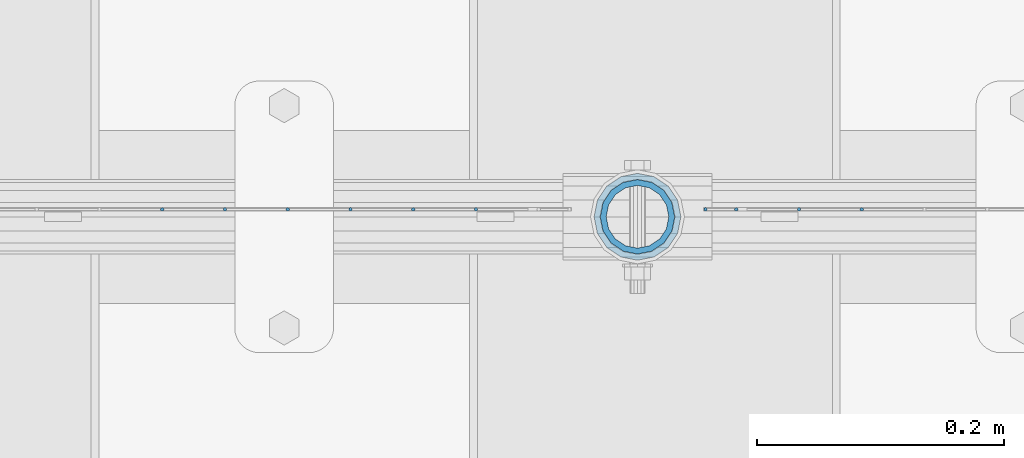
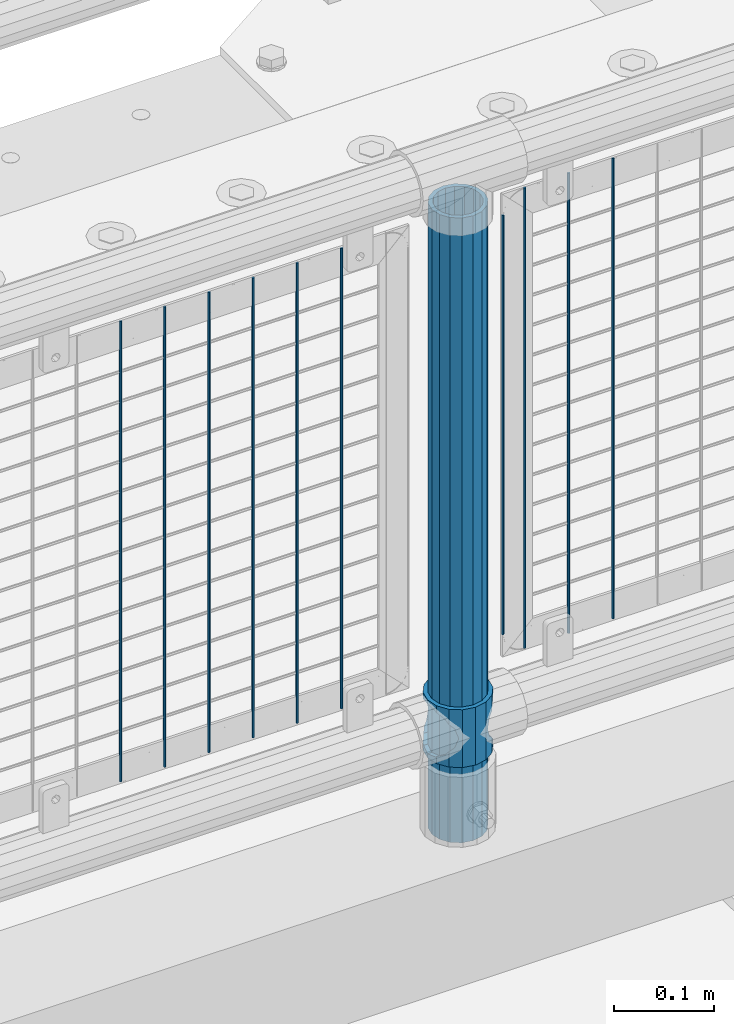
# One storey, part 79 of 242: 12 columns.
"""IFC2X3 building model written with IfcOpenShell, lengths in millimetres."""

import ifcopenshell
import ifcopenshell.guid

model = None  # the IFC model being written
_history = None  # IfcOwnerHistory: only IFC2X3 demands one
_inside = {}  # id of a spatial element -> (the spatial element, [elements in it])
_under = {}  # id of a project, library or spatial element -> (it, [spatial elements below it])
_declared = {}  # id of a project -> (the project, [libraries it declares])
_typed = {}  # id of a type object -> (the type object, [elements of that type])
_made_of = {}  # id of a material, layer set ... -> (it, [elements and type objects made of it])


def new_model(schema):
    """Start an empty IFC model of exactly this schema.

    Asked for "IFC4X3", IfcOpenShell would pick the latest addendum, in which some entities
    have other attributes; the version numbers below select the first issue.
    IFC2X3 requires an IfcOwnerHistory on every rooted entity: one is made here for all.
    """
    global model, _history
    if schema == "IFC4X3":
        model = ifcopenshell.file(schema_version=(4, 3, 0, 0))
    else:
        model = ifcopenshell.file(schema=schema)
    _inside.clear()
    _under.clear()
    _declared.clear()
    _typed.clear()
    _made_of.clear()
    _history = None
    if model.schema == "IFC2X3":
        org = make("IfcOrganization", Name="unknown")
        user = make(
            "IfcPersonAndOrganization",
            ThePerson=make("IfcPerson", FamilyName="unknown"),
            TheOrganization=org,
        )
        app = make(
            "IfcApplication",
            ApplicationDeveloper=org,
            Version="unknown",
            ApplicationFullName="unknown",
            ApplicationIdentifier="unknown",
        )
        _history = make(
            "IfcOwnerHistory",
            OwningUser=user,
            OwningApplication=app,
            ChangeAction="ADDED",
            CreationDate=0,
        )
    return model


def make(cls, **values):
    """One entity of the class cls with the attributes given. An attribute that is None is left unset."""
    return model.create_entity(
        cls, **{name: value for name, value in values.items() if value is not None}
    )


def rooted(cls, **values):
    """An entity with a GlobalId (a new one), such as an element, a storey or a relation."""
    return make(cls, GlobalId=ifcopenshell.guid.new(), OwnerHistory=_history, **values)


def si_unit(unit_type, name, prefix=None):
    """IfcSIUnit, for example si_unit("LENGTHUNIT", "METRE", prefix="MILLI")."""
    return make("IfcSIUnit", UnitType=unit_type, Prefix=prefix, Name=name)


def assignment(units):
    """IfcUnitAssignment: the units of a project."""
    return None if units is None else make("IfcUnitAssignment", Units=units)


def point(xyz):
    """IfcCartesianPoint."""
    return None if xyz is None else make("IfcCartesianPoint", Coordinates=xyz)


def direction(xyz):
    """IfcDirection."""
    return None if xyz is None else make("IfcDirection", DirectionRatios=xyz)


def frame(location, z_axis=None, x_axis=None):
    """IfcAxis2Placement3D, a coordinate frame: its origin and axes. An axis left out is left unset."""
    return make(
        "IfcAxis2Placement3D",
        Location=point(location),
        Axis=direction(z_axis),
        RefDirection=direction(x_axis),
    )


def origin_with_axes():
    """The frame at (0, 0, 0) with the z axis (0, 0, 1) and the x axis (1, 0, 0) written out."""
    return frame((0.0, 0.0, 0.0), z_axis=(0.0, 0.0, 1.0), x_axis=(1.0, 0.0, 0.0))


def place(relative_to, where):
    """IfcLocalPlacement: puts the frame where relative to a parent placement (None: the world)."""
    return make(
        "IfcLocalPlacement", PlacementRelTo=relative_to, RelativePlacement=where
    )


def context(
    kind, dimensions, precision=None, world=None, true_north=None, identifier=None
):
    """IfcGeometricRepresentationContext, for example the 3D "Model" context."""
    return make(
        "IfcGeometricRepresentationContext",
        ContextIdentifier=identifier,
        ContextType=kind,
        CoordinateSpaceDimension=dimensions,
        Precision=precision,
        WorldCoordinateSystem=world,
        TrueNorth=true_north,
    )


def subcontext(parent, identifier, kind, view, scale=None):
    """IfcGeometricRepresentationSubContext, for example "Body" below "Model"."""
    return make(
        "IfcGeometricRepresentationSubContext",
        ContextIdentifier=identifier,
        ContextType=kind,
        ParentContext=parent,
        TargetScale=scale,
        TargetView=view,
    )


def project(units=None, contexts=None):
    """IfcProject with its units and contexts."""
    return rooted(
        "IfcProject",
        Name="project",
        RepresentationContexts=contexts,
        UnitsInContext=assignment(units),
    )


def spatial(cls, under=None, at=None, **own):
    """A site, building, storey or space (cls), placed at a placement, below another one or the project."""
    s = rooted(cls, ObjectPlacement=at, **own)
    if under is not None:
        _under.setdefault(under.id(), (under, []))[1].append(s)
    return s


def faces_of(points, faces, orient=None, outer=None):
    """IfcFace entities. A face is a list of loops; a loop is a list of indices into points, from 0.

    orient and outer hold one flag for each loop. By default every Orientation is true, the
    first loop of a face is its IfcFaceOuterBound and the others are IfcFaceBound.
    """
    made = []
    for i, loops in enumerate(faces):
        bounds = []
        for j, loop in enumerate(loops):
            is_outer = j == 0 if outer is None else outer[i][j]
            bounds.append(
                make(
                    "IfcFaceOuterBound" if is_outer else "IfcFaceBound",
                    Bound=make("IfcPolyLoop", Polygon=[points[k] for k in loop]),
                    Orientation=True if orient is None else orient[i][j],
                )
            )
        made.append(make("IfcFace", Bounds=bounds))
    return made


def faceted_brep(points, faces, orient=None, outer=None, voids=None):
    """IfcFacetedBrep: a solid bounded by flat faces; with voids (closed shells), ...WithVoids."""
    shared = [point(p) for p in points]
    hull = make("IfcClosedShell", CfsFaces=faces_of(shared, faces, orient, outer))
    if voids is None:
        return make("IfcFacetedBrep", Outer=hull)
    return make(
        "IfcFacetedBrepWithVoids",
        Outer=hull,
        Voids=[
            make(cls, CfsFaces=faces_of(shared, fs, o, b)) for cls, fs, o, b in voids
        ],
    )


def shape(context_of_items, identifier, shape_type, items):
    """IfcShapeRepresentation: the items that make up one representation, for example the "Body"."""
    return make(
        "IfcShapeRepresentation",
        ContextOfItems=context_of_items,
        RepresentationIdentifier=identifier,
        RepresentationType=shape_type,
        Items=items,
    )


def material(Name=None, Category=None):
    """IfcMaterial."""
    return make("IfcMaterial", Name=Name, Category=Category)


def made_of(thing, what):
    """Note that an element or type object is made of a material, layer set ...; save() writes the relation."""
    if what is not None:
        _made_of.setdefault(what.id(), (what, []))[1].append(thing)
    return thing


def type_object(cls, material=None, **own):
    """A type object (cls), such as IfcWallType, which elements share."""
    return made_of(rooted(cls, **own), material)


def element(
    cls,
    number,
    at=None,
    inside=None,
    cuts=None,
    type_object=None,
    material=None,
    context=None,
    identifier="Body",
    shape_type=None,
    held_by="IfcProductDefinitionShape",
    body=None,
    shapes=None,
    **own,
):
    """One element of the class cls, such as IfcWall. Its Tag is "e" and its number.

    at: its placement. inside: the storey or other place that contains it. cuts: it is an
    opening in that element (IfcRelVoidsElement). A single representation is given by context,
    identifier, shape_type and body (its items); several are given by shapes. held_by: the class
    of the entity that holds the representations. save() writes the other relations.
    """
    e = rooted(cls, Tag="e%d" % number, ObjectPlacement=at, **own)
    if body is not None:
        shapes = [shape(context, identifier, shape_type, body)]
    if shapes is not None:
        e.Representation = make(held_by, Representations=shapes)
    if inside is not None:
        _inside.setdefault(inside.id(), (inside, []))[1].append(e)
    if cuts is not None:
        rooted(
            "IfcRelVoidsElement", RelatingBuildingElement=cuts, RelatedOpeningElement=e
        )
    if type_object is not None:
        _typed.setdefault(type_object.id(), (type_object, []))[1].append(e)
    return made_of(e, material)


def aggregate(whole, parts):
    """IfcRelAggregates: a whole, such as a stair, and the parts it consists of."""
    return rooted("IfcRelAggregates", RelatingObject=whole, RelatedObjects=parts)


def save(model, path):
    """Write the relations noted so far, then the file.

    IfcRelAggregates (storeys below a building ...), IfcRelContainedInSpatialStructure (elements
    in a storey), IfcRelDefinesByType, IfcRelAssociatesMaterial and IfcRelDeclares: one each for
    every whole, place, type object, material and project.
    """
    for whole, parts in _under.values():
        aggregate(whole, parts)
    for where, things in _inside.values():
        rooted(
            "IfcRelContainedInSpatialStructure",
            RelatedElements=things,
            RelatingStructure=where,
        )
    for kind, things in _typed.values():
        rooted("IfcRelDefinesByType", RelatedObjects=things, RelatingType=kind)
    for what, things in _made_of.values():
        rooted("IfcRelAssociatesMaterial", RelatedObjects=things, RelatingMaterial=what)
    for by, libraries in _declared.values():
        rooted("IfcRelDeclares", RelatingContext=by, RelatedDefinitions=libraries)
    model.write(path)


model = new_model("IFC2X3")

# Units and contexts
model_context = context("Model", 3, precision=1e-05, world=origin_with_axes())
body_context = subcontext(model_context, "Body", "Model", "MODEL_VIEW")
ifc_project = project(units=[si_unit("LENGTHUNIT", "METRE", prefix="MILLI"), si_unit("AREAUNIT", "SQUARE_METRE"), si_unit("VOLUMEUNIT", "CUBIC_METRE"), si_unit("MASSUNIT", "GRAM", prefix="KILO"), si_unit("TIMEUNIT", "SECOND"), si_unit("PLANEANGLEUNIT", "RADIAN"), si_unit("SOLIDANGLEUNIT", "STERADIAN"), si_unit("THERMODYNAMICTEMPERATUREUNIT", "DEGREE_CELSIUS"), si_unit("LUMINOUSINTENSITYUNIT", "LUMEN")], contexts=[model_context])

# Site, building, storey
site_placement = place(None, origin_with_axes())
site = spatial("IfcSite", under=ifc_project, at=site_placement, CompositionType="ELEMENT")
building_placement = place(site_placement, origin_with_axes())
building = spatial("IfcBuilding", under=site, at=building_placement, Name="Standard", CompositionType="ELEMENT")
storey_placement = place(building_placement, origin_with_axes())
storey = spatial("IfcBuildingStorey", under=building, at=storey_placement, Name="Undefined", CompositionType="ELEMENT", Elevation=0.0)

# Columns
ifc_material_1 = material()
column_type_1 = type_object("IfcColumnType", PredefinedType="NOTDEFINED")
column_1_placement = place(storey_placement, frame((-33664.0, -19335.5, 168.02), z_axis=(-1.0, 0.0, 0.0), x_axis=(0.0, 0.0, 1.0)))
element("IfcColumn", 1, at=column_1_placement, inside=storey, type_object=column_type_1, material=ifc_material_1, context=body_context, shape_type="Brep", body=[
    faceted_brep([(0.0, -25.3499999999985, 0.0), (0.0, -23.4203461491597, 9.70102501045403), (760.0, -23.4203461491597, 9.70102501045403), (760.0, -25.3499999999985, 0.0), (0.0, -17.9251569030785, 17.9251569030785), (760.0, -17.9251569030785, 17.9251569030785), (0.0, -9.70102501045403, 23.4203461491597), (760.0, -9.70102501045403, 23.4203461491597), (0.0, 0.0, 25.3499999999985), (760.0, 0.0, 25.3499999999985), (0.0, 9.70102501045403, 23.4203461491597), (760.0, 9.70102501045403, 23.4203461491597), (0.0, 17.9251569030785, 17.9251569030785), (760.0, 17.9251569030785, 17.9251569030785), (0.0, 23.4203461491597, 9.70102501045403), (760.0, 23.4203461491597, 9.70102501045403), (0.0, 25.3499999999985, 0.0), (760.0, 25.3499999999985, 0.0), (0.0, 23.4203461491597, -9.70102501045403), (760.0, 23.4203461491597, -9.70102501045403), (0.0, 17.9251569030785, -17.9251569030785), (760.0, 17.9251569030785, -17.9251569030785), (0.0, 9.70102501045403, -23.4203461491597), (760.0, 9.70102501045403, -23.4203461491597), (0.0, 0.0, -25.3499999999985), (760.0, 0.0, -25.3499999999985), (0.0, -9.70102501045403, -23.4203461491597), (760.0, -9.70102501045403, -23.4203461491597), (0.0, -17.9251569030785, -17.9251569030785), (760.0, -17.9251569030785, -17.9251569030785), (0.0, -23.4203461491597, -9.70102501045403), (760.0, -23.4203461491597, -9.70102501045403), (0.0, -30.1500000000015, 0.0), (0.0, -27.8549679052157, -11.5379054858058), (760.0, -27.8549679052157, -11.5379054858058), (760.0, -30.1500000000015, 0.0), (0.0, -21.3192694527752, -21.3192694527752), (760.0, -21.3192694527752, -21.3192694527752), (0.0, -11.5379054858058, -27.8549679052157), (760.0, -11.5379054858058, -27.8549679052157), (0.0, 0.0, -30.1500000000015), (760.0, 0.0, -30.1500000000015), (0.0, 11.5379054858058, -27.8549679052157), (760.0, 11.5379054858058, -27.8549679052157), (0.0, 21.3192694527752, -21.3192694527752), (760.0, 21.3192694527752, -21.3192694527752), (0.0, 27.8549679052157, -11.5379054858058), (760.0, 27.8549679052157, -11.5379054858058), (0.0, 30.1500000000015, 0.0), (760.0, 30.1500000000015, 0.0), (0.0, 27.8549679052157, 11.5379054858058), (760.0, 27.8549679052157, 11.5379054858058), (0.0, 21.3192694527752, 21.3192694527752), (760.0, 21.3192694527752, 21.3192694527752), (0.0, 11.5379054858058, 27.8549679052157), (760.0, 11.5379054858058, 27.8549679052157), (0.0, 0.0, 30.1500000000015), (760.0, 0.0, 30.1500000000015), (0.0, -11.5379054858058, 27.8549679052157), (760.0, -11.5379054858058, 27.8549679052157), (0.0, -21.3192694527752, 21.3192694527752), (760.0, -21.3192694527752, 21.3192694527752), (0.0, -27.8549679052157, 11.5379054858058), (760.0, -27.8549679052157, 11.5379054858058)], [[[0, 1, 2, 3]], [[1, 4, 5, 2]], [[4, 6, 7, 5]], [[6, 8, 9, 7]], [[8, 10, 11, 9]], [[10, 12, 13, 11]], [[12, 14, 15, 13]], [[14, 16, 17, 15]], [[16, 18, 19, 17]], [[18, 20, 21, 19]], [[20, 22, 23, 21]], [[22, 24, 25, 23]], [[24, 26, 27, 25]], [[26, 28, 29, 27]], [[28, 30, 31, 29]], [[30, 0, 3, 31]], [[32, 33, 34, 35]], [[33, 36, 37, 34]], [[36, 38, 39, 37]], [[38, 40, 41, 39]], [[40, 42, 43, 41]], [[42, 44, 45, 43]], [[44, 46, 47, 45]], [[46, 48, 49, 47]], [[48, 50, 51, 49]], [[50, 52, 53, 51]], [[52, 54, 55, 53]], [[54, 56, 57, 55]], [[56, 58, 59, 57]], [[58, 60, 61, 59]], [[60, 62, 63, 61]], [[62, 32, 35, 63]], [[37, 39, 41, 43, 45, 47, 49, 51, 53, 55, 57, 59, 61, 63, 35, 34], [5, 7, 9, 11, 13, 15, 17, 19, 21, 23, 25, 27, 29, 31, 3, 2]], [[62, 60, 58, 56, 54, 52, 50, 48, 46, 44, 42, 40, 38, 36, 33, 32], [30, 28, 26, 24, 22, 20, 18, 16, 14, 12, 10, 8, 6, 4, 1, 0]]]),
])
ifc_material_2 = material(Name="Misc_Undefined")
column_type_2 = type_object("IfcColumnType", PredefinedType="NOTDEFINED")
column_2_placement = place(storey_placement, frame((-33664.0, -19335.5, 263.02), z_axis=(-1.0, 0.0, 0.0), x_axis=(0.0, 0.0, 1.0)))
element("IfcColumn", 2, at=column_2_placement, inside=storey, type_object=column_type_2, material=ifc_material_2, context=body_context, shape_type="Brep", body=[
    faceted_brep([(63.1897438117172, 11.614442172282, -32.8397438117245), (63.1897438117172, 11.614442172282, -28.0397438117143), (56.6106908090114, 21.46069080901, -21.4606908090136), (56.6106908090114, 21.46069080901, -27.1226768591077), (61.9623795176744, 13.4513226476338, -32.4743655677739), (46.7644421722801, 28.0397438117179, -11.6144421722784), (46.7644421722801, 28.0397438117179, -20.0882031229849), (51.5310424080006, 24.8548033587067, -24.8548033587067), (35.1500000000015, 30.35, 0.0), (35.1499999999996, 30.3499999999985, -16.6306603983685), (23.5355578277192, 28.0397438117179, -11.6144421722784), (23.5355578277192, 28.0397438117179, -20.0882031229849), (18.7689575919987, 24.8548033587067, -24.8548033587067), (13.6893091909879, 21.46069080901, -21.4606908090136), (13.6893091909879, 21.46069080901, -27.1226768591077), (8.33762048232262, 13.4513226476338, -32.4743655677739), (7.11025618828211, 11.614442172282, -28.0397438117143), (7.11025618828211, 11.614442172282, -32.8397438117245), (4.79999999999961, 0.0, -30.3499999999985), (4.79999999999961, 0.0, -35.1500000000015), (7.11025618828211, -11.614442172282, -28.0397438117143), (7.11025618828211, -11.614442172282, -32.8397438117172), (13.6893091909879, -21.46069080901, -21.4606908090136), (13.6893091909879, -21.46069080901, -27.1226768591077), (8.33762048232484, -13.4513226476338, -32.4743655677739), (23.5355578277191, -28.0397438117179, -11.6144421722784), (23.5355578277191, -28.0397438117179, -20.0882031229921), (18.7689575919975, -24.8548033587067, -24.8548033587067), (35.1500000000015, -30.35, 0.0), (35.1499999999996, -30.3499999999985, -16.6306603983758), (46.7644421722801, -28.0397438117179, -11.6144421722784), (46.7644421722801, -28.0397438117179, -20.0882031229921), (51.5310424079973, -24.8548033587067, -24.8548033587067), (56.6106908090114, -21.46069080901, -21.4606908090136), (56.6106908090114, -21.46069080901, -27.1226768591077), (61.9623795176767, -13.4513226476338, -32.4743655677739), (63.1897438117172, -11.614442172282, -28.0397438117143), (63.1897438117172, -11.614442172282, -32.8397438117172), (65.4999999999997, 0.0, -30.3499999999985), (65.4999999999997, 0.0, -35.1500000000015), (0.0, -28.0397438117179, -11.6144421722784), (0.0, -30.3499999999985, 0.0), (0.0, -21.46069080901, -21.4606908090136), (0.0, -11.614442172282, -28.0397438117143), (0.0, 0.0, -30.3499999999985), (0.0, 11.614442172282, -28.0397438117143), (0.0, 21.46069080901, -21.4606908090136), (0.0, 28.0397438117179, -11.6144421722784), (0.0, 30.3499999999985, 0.0), (0.0, 28.0397438117179, 11.6144421722784), (23.5355578277192, 28.0397438117179, 11.614442172282), (0.0, 21.46069080901, 21.4606908090136), (13.6893091909879, 21.46069080901, 21.46069080901), (0.0, 11.614442172282, 28.0397438117143), (7.11025618828211, 11.614442172282, 28.0397438117179), (0.0, 0.0, 30.3499999999985), (4.79999999999961, 0.0, 30.3499999999985), (0.0, -11.614442172282, 28.0397438117143), (7.11025618828205, -11.614442172282, 28.0397438117179), (0.0, -21.46069080901, 21.4606908090136), (13.6893091909879, -21.46069080901, 21.46069080901), (0.0, -28.0397438117179, 11.6144421722784), (23.5355578277191, -28.0397438117179, 11.614442172282), (0.0, -32.4743655677703, 13.4513226476338), (0.0, -35.1500000000015, 0.0), (70.2999999999993, -35.1500000000015, 0.0), (70.2999999999993, -32.4743655677703, 13.4513226476338), (0.0, 13.4513226476338, -32.4743655677739), (0.0, 24.8548033587067, -24.8548033587067), (0.0, 0.0, -35.1500000000015), (0.0, -13.4513226476338, -32.4743655677739), (0.0, -24.8548033587067, -24.8548033587067), (0.0, -24.8548033587067, 24.8548033587067), (0.0, -13.4513226476338, 32.4743655677739), (0.0, 0.0, 35.1500000000015), (0.0, 13.4513226476338, 32.4743655677739), (0.0, 24.8548033587067, 24.8548033587067), (0.0, 32.4743655677703, 13.4513226476338), (0.0, 35.1500000000015, 0.0), (0.0, 32.4743655677703, -13.4513226476338), (0.0, -32.4743655677703, -13.4513226476338), (70.2999999999993, 32.4743655677703, 13.4513226476338), (70.2999999999993, 35.1500000000015, 0.0), (70.2999999999993, 32.4743655677703, -13.4513226476338), (70.2999999999993, 24.8548033587067, -24.8548033587067), (70.2999999999993, 13.4513226476338, -32.4743655677739), (70.2999999999993, 0.0, -35.1500000000015), (70.2999999999993, -13.4513226476338, -32.4743655677739), (70.2999999999993, -24.8548033587067, -24.8548033587067), (70.2999999999993, -32.4743655677703, -13.4513226476338), (70.2999999999993, 28.0397438117179, 11.6144421722784), (70.2999999999993, 21.46069080901, 21.4606908090136), (56.6106908090114, 21.46069080901, 21.46069080901), (46.7644421722801, 28.0397438117179, 11.614442172282), (70.2999999999993, 11.614442172282, 28.0397438117143), (63.1897438117172, 11.614442172282, 28.0397438117179), (70.2999999999993, 0.0, 30.3499999999985), (65.4999999999997, 0.0, 30.3499999999985), (70.2999999999993, -11.614442172282, 28.0397438117143), (63.1897438117172, -11.614442172282, 28.0397438117179), (70.2999999999993, -21.46069080901, 21.4606908090136), (56.6106908090114, -21.46069080901, 21.46069080901), (70.2999999999993, -28.0397438117179, 11.6144421722784), (46.7644421722801, -28.0397438117179, 11.614442172282), (70.2999999999993, -11.614442172282, -28.0397438117143), (70.2999999999993, 0.0, -30.3499999999985), (70.2999999999993, -21.46069080901, -21.4606908090136), (70.2999999999993, -28.0397438117179, -11.6144421722784), (70.2999999999993, -30.3499999999985, 0.0), (70.2999999999993, 24.8548033587067, 24.8548033587067), (70.2999999999993, 13.4513226476338, 32.4743655677739), (70.2999999999993, 0.0, 35.1500000000015), (70.2999999999993, -13.4513226476338, 32.4743655677739), (70.2999999999993, -24.8548033587067, 24.8548033587067), (70.2999999999993, 30.3499999999985, 0.0), (70.2999999999993, 28.0397438117179, -11.6144421722784), (70.2999999999993, 21.46069080901, -21.4606908090136), (70.2999999999993, 11.614442172282, -28.0397438117143), (61.9623795176744, 13.4513226476338, 32.4743655677703), (51.5310424080006, 24.8548033587067, 24.8548033587067), (56.6106908090114, 21.46069080901, 27.1226768591077), (65.4999999999997, 0.0, 35.1500000000015), (63.1897438117172, 11.614442172282, 32.8397438117136), (63.1897438117172, -11.614442172282, 32.8397438117172), (61.9623795176767, -13.4513226476338, 32.4743655677703), (56.6106908090114, -21.46069080901, 27.1226768591077), (51.5310424080038, -24.8548033587067, 24.8548033587067), (18.7689575919954, -24.8548033587067, 24.8548033587067), (46.7644421722801, -28.0397438117179, 20.0882031229885), (35.1499999999996, -30.3499999999985, 16.6306603983685), (23.5355578277191, -28.0397438117179, 20.0882031229885), (8.33762048232484, -13.4513226476338, 32.4743655677703), (13.6893091909879, -21.46069080901, 27.1226768591077), (4.79999999999961, 0.0, 35.1500000000015), (7.11025618828205, -11.614442172282, 32.8397438117172), (7.11025618828211, 11.614442172282, 32.8397438117136), (8.33762048232262, 13.4513226476338, 32.4743655677703), (13.6893091909879, 21.46069080901, 27.1226768591077), (18.768957592002, 24.8548033587067, 24.8548033587067), (23.5355578277192, 28.0397438117179, 20.0882031229812), (35.1499999999996, 30.3499999999985, 16.6306603983721), (46.7644421722801, 28.0397438117179, 20.0882031229812)], [[[0, 1, 2, 3, 4]], [[3, 2, 5, 6, 7]], [[6, 5, 8, 9]], [[9, 8, 10, 11]], [[12, 11, 10, 13, 14]], [[15, 14, 13, 16, 17]], [[17, 16, 18, 19]], [[19, 18, 20, 21]], [[21, 20, 22, 23, 24]], [[23, 22, 25, 26, 27]], [[26, 25, 28, 29]], [[29, 28, 30, 31]], [[32, 31, 30, 33, 34]], [[35, 34, 33, 36, 37]], [[37, 36, 38, 39]], [[39, 38, 1, 0]], [[40, 41, 28, 25]], [[42, 40, 25, 22]], [[43, 42, 22, 20]], [[44, 43, 20, 18]], [[45, 44, 18, 16]], [[46, 45, 16, 13]], [[47, 46, 13, 10]], [[48, 47, 10, 8]], [[49, 48, 8, 50]], [[51, 49, 50, 52]], [[53, 51, 52, 54]], [[55, 53, 54, 56]], [[57, 55, 56, 58]], [[59, 57, 58, 60]], [[61, 59, 60, 62]], [[41, 61, 62, 28]], [[63, 64, 65, 66]], [[67, 68, 12, 14, 15]], [[69, 67, 15, 17, 19]], [[24, 70, 69, 19, 21]], [[27, 71, 70, 24, 23]], [[63, 72, 73, 74, 75, 76, 77, 78, 79, 68, 67, 69, 70, 71, 80, 64], [40, 42, 43, 44, 45, 46, 47, 48, 49, 51, 53, 55, 57, 59, 61, 41]], [[78, 77, 81, 82]], [[79, 78, 82, 83]], [[68, 79, 83, 84, 7, 6, 9, 11, 12]], [[7, 84, 85, 4, 3]], [[4, 85, 86, 39, 0]], [[87, 88, 32, 34, 35]], [[86, 87, 35, 37, 39]], [[29, 31, 32, 88, 89, 80, 71, 27, 26]], [[64, 80, 89, 65]], [[90, 91, 92, 93]], [[91, 94, 95, 92]], [[94, 96, 97, 95]], [[96, 98, 99, 97]], [[98, 100, 101, 99]], [[100, 102, 103, 101]], [[104, 105, 38, 36]], [[106, 104, 36, 33]], [[107, 106, 33, 30]], [[108, 107, 30, 28]], [[102, 108, 28, 103]], [[88, 87, 86, 85, 84, 83, 82, 81, 109, 110, 111, 112, 113, 66, 65, 89], [100, 98, 96, 94, 91, 90, 114, 115, 116, 117, 105, 104, 106, 107, 108, 102]], [[118, 110, 109, 119, 120]], [[121, 111, 110, 118, 122]], [[112, 111, 121, 123, 124]], [[113, 112, 124, 125, 126]], [[127, 72, 63, 66, 113, 126, 128, 129, 130]], [[131, 73, 72, 127, 132]], [[133, 74, 73, 131, 134]], [[75, 74, 133, 135, 136]], [[76, 75, 136, 137, 138]], [[119, 109, 81, 77, 76, 138, 139, 140, 141]], [[92, 120, 119, 141, 93]], [[95, 122, 118, 120, 92]], [[97, 121, 122, 95]], [[99, 123, 121, 97]], [[101, 125, 124, 123, 99]], [[103, 128, 126, 125, 101]], [[28, 129, 128, 103]], [[62, 130, 129, 28]], [[60, 132, 127, 130, 62]], [[58, 134, 131, 132, 60]], [[56, 133, 134, 58]], [[54, 135, 133, 56]], [[52, 137, 136, 135, 54]], [[50, 139, 138, 137, 52]], [[8, 140, 139, 50]], [[93, 141, 140, 8]], [[114, 90, 93, 8]], [[115, 114, 8, 5]], [[116, 115, 5, 2]], [[117, 116, 2, 1]], [[105, 117, 1, 38]]]),
])
column_type_3 = type_object("IfcColumnType", Name="D3", PredefinedType="NOTDEFINED")
for number, where, z_axis, x_axis in (
    (3, (-33482.414, -19329.5, 353.02), (-1.0, 0.0, 0.0), (0.0, 0.0, 1.0)),
    (4, (-33533.207, -19329.5, 353.02), (-1.0, 0.0, 0.0), (0.0, 0.0, 1.0)),
):
    element("IfcColumn", number, at=place(storey_placement, frame(where, z_axis=z_axis, x_axis=x_axis)), inside=storey, type_object=column_type_3, material=ifc_material_2, ObjectType="D3", context=body_context, shape_type="Brep", body=[
        faceted_brep([(0.0, -1.50000000000364, 0.0), (-3.63797880709171e-12, -0.750000000003638, -1.29903810567669), (560.0, -0.75, -1.29903810567703), (560.0, -1.5, 0.0), (0.0, 0.749999999996362, -1.29903810567669), (560.0, 0.75, -1.29903810567703), (-3.63797880709171e-12, 1.49999999999636, 0.0), (560.0, 1.5, 0.0), (0.0, 0.749999999996362, 1.29903810567669), (560.0, 0.75, 1.29903810567703), (-3.63797880709171e-12, -0.750000000003638, 1.29903810567669), (560.0, -0.75, 1.29903810567703)], [[[0, 1, 2, 3]], [[1, 4, 5, 2]], [[4, 6, 7, 5]], [[6, 8, 9, 7]], [[8, 10, 11, 9]], [[10, 0, 3, 11]], [[5, 7, 9, 11, 3, 2]], [[10, 8, 6, 4, 1, 0]]]),
    ])
column_3_placement = place(storey_placement, frame((-33609.0, -19329.5, 378.02), z_axis=(-1.0, 0.0, 0.0), x_axis=(0.0, 0.0, 1.0)))
element("IfcColumn", 5, at=column_3_placement, inside=storey, type_object=column_type_3, material=ifc_material_2, ObjectType="D3", context=body_context, shape_type="Brep", body=[
    faceted_brep([(0.0, -1.50000000000364, 0.0), (-3.63797880709171e-12, -0.750000000003638, -1.29903810567669), (510.0, -0.75, -1.29903810567703), (510.0, -1.5, 0.0), (0.0, 0.749999999996362, -1.29903810567669), (510.0, 0.75, -1.29903810567703), (-3.63797880709171e-12, 1.49999999999636, 0.0), (510.0, 1.5, 0.0), (0.0, 0.749999999996362, 1.29903810567669), (510.0, 0.75, 1.29903810567703), (-3.63797880709171e-12, -0.750000000003638, 1.29903810567669), (510.0, -0.75, 1.29903810567703)], [[[0, 1, 2, 3]], [[1, 4, 5, 2]], [[4, 6, 7, 5]], [[6, 8, 9, 7]], [[8, 10, 11, 9]], [[10, 0, 3, 11]], [[5, 7, 9, 11, 3, 2]], [[10, 8, 6, 4, 1, 0]]]),
])
for number, where, z_axis, x_axis in (
    (6, (-33584.0, -19329.5, 353.02), (-1.0, 0.0, 0.0), (0.0, 0.0, 1.0)),
    (7, (-33794.796, -19329.5, 353.02), (-1.0, 0.0, 0.0), (0.0, 0.0, 1.0)),
    (8, (-33845.589, -19329.5, 353.02), (-1.0, 0.0, 0.0), (0.0, 0.0, 1.0)),
    (9, (-33896.382, -19329.5, 353.02), (-1.0, 0.0, 0.0), (0.0, 0.0, 1.0)),
    (10, (-33947.175, -19329.5, 353.02), (-1.0, 0.0, 0.0), (0.0, 0.0, 1.0)),
    (11, (-33997.968, -19329.5, 353.02), (-1.0, 0.0, 0.0), (0.0, 0.0, 1.0)),
    (12, (-34048.761, -19329.5, 353.02), (-1.0, 0.0, 0.0), (0.0, 0.0, 1.0)),
):
    element("IfcColumn", number, at=place(storey_placement, frame(where, z_axis=z_axis, x_axis=x_axis)), inside=storey, type_object=column_type_3, material=ifc_material_2, ObjectType="D3", context=body_context, shape_type="Brep", body=[
        faceted_brep([(0.0, -1.50000000000364, 0.0), (-3.63797880709171e-12, -0.750000000003638, -1.29903810567669), (560.0, -0.75, -1.29903810567703), (560.0, -1.5, 0.0), (0.0, 0.749999999996362, -1.29903810567669), (560.0, 0.75, -1.29903810567703), (-3.63797880709171e-12, 1.49999999999636, 0.0), (560.0, 1.5, 0.0), (0.0, 0.749999999996362, 1.29903810567669), (560.0, 0.75, 1.29903810567703), (-3.63797880709171e-12, -0.750000000003638, 1.29903810567669), (560.0, -0.75, 1.29903810567703)], [[[0, 1, 2, 3]], [[1, 4, 5, 2]], [[4, 6, 7, 5]], [[6, 8, 9, 7]], [[8, 10, 11, 9]], [[10, 0, 3, 11]], [[5, 7, 9, 11, 3, 2]], [[10, 8, 6, 4, 1, 0]]]),
    ])

save(model, "model.ifc")
